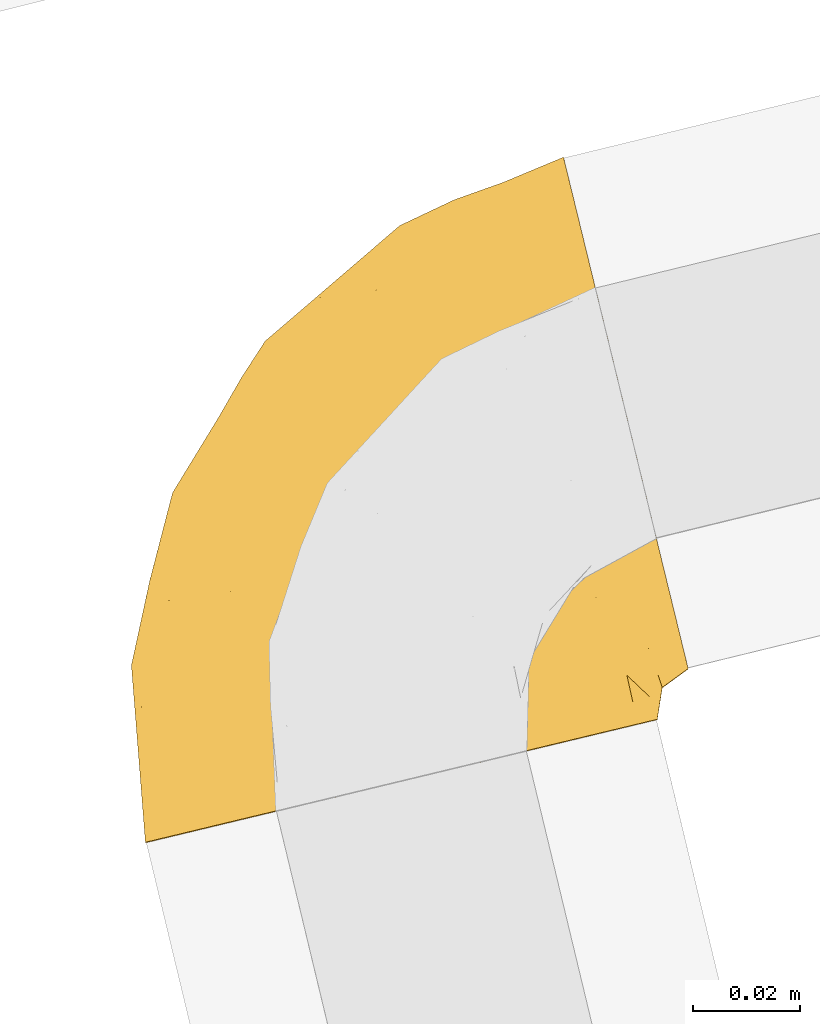
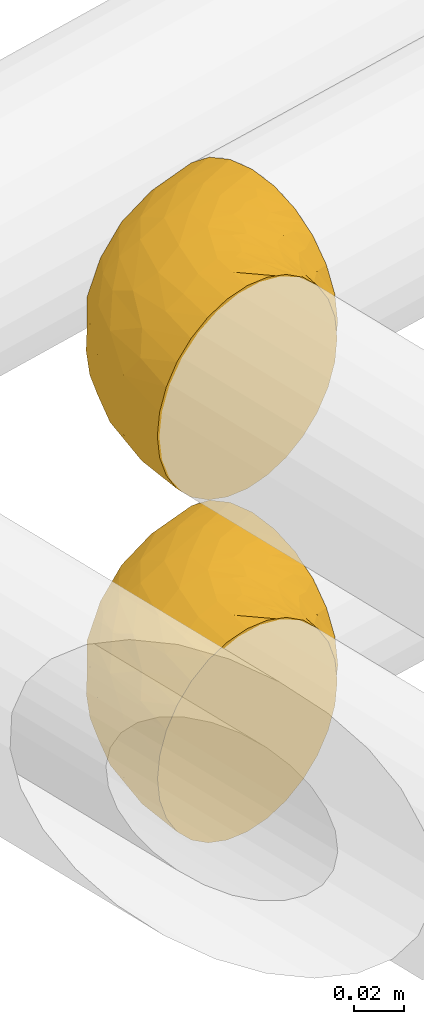
# One storey, part 10 of 93: 2 coverings.
"""IFC2X3 building model written with IfcOpenShell, lengths in millimetres."""

import ifcopenshell
import ifcopenshell.guid

model = None  # the IFC model being written
_history = None  # IfcOwnerHistory: only IFC2X3 demands one
_inside = {}  # id of a spatial element -> (the spatial element, [elements in it])
_under = {}  # id of a project, library or spatial element -> (it, [spatial elements below it])
_declared = {}  # id of a project -> (the project, [libraries it declares])
_typed = {}  # id of a type object -> (the type object, [elements of that type])
_made_of = {}  # id of a material, layer set ... -> (it, [elements and type objects made of it])


def new_model(schema):
    """Start an empty IFC model of exactly this schema.

    Asked for "IFC4X3", IfcOpenShell would pick the latest addendum, in which some entities
    have other attributes; the version numbers below select the first issue.
    IFC2X3 requires an IfcOwnerHistory on every rooted entity: one is made here for all.
    """
    global model, _history
    if schema == "IFC4X3":
        model = ifcopenshell.file(schema_version=(4, 3, 0, 0))
    else:
        model = ifcopenshell.file(schema=schema)
    _inside.clear()
    _under.clear()
    _declared.clear()
    _typed.clear()
    _made_of.clear()
    _history = None
    if model.schema == "IFC2X3":
        org = make("IfcOrganization", Name="unknown")
        user = make(
            "IfcPersonAndOrganization",
            ThePerson=make("IfcPerson", FamilyName="unknown"),
            TheOrganization=org,
        )
        app = make(
            "IfcApplication",
            ApplicationDeveloper=org,
            Version="unknown",
            ApplicationFullName="unknown",
            ApplicationIdentifier="unknown",
        )
        _history = make(
            "IfcOwnerHistory",
            OwningUser=user,
            OwningApplication=app,
            ChangeAction="ADDED",
            CreationDate=0,
        )
    return model


def make(cls, **values):
    """One entity of the class cls with the attributes given. An attribute that is None is left unset."""
    return model.create_entity(
        cls, **{name: value for name, value in values.items() if value is not None}
    )


def entity(cls, *values):
    """Any entity or typed value of the class cls, its attributes in the order of the schema. None: left unset."""
    e = model.create_entity(cls)
    for i, value in enumerate(values):
        if value is not None:
            e[i] = value
    return e


def rooted(cls, **values):
    """An entity with a GlobalId (a new one), such as an element, a storey or a relation."""
    return make(cls, GlobalId=ifcopenshell.guid.new(), OwnerHistory=_history, **values)


def si_unit(unit_type, name, prefix=None):
    """IfcSIUnit, for example si_unit("LENGTHUNIT", "METRE", prefix="MILLI")."""
    return make("IfcSIUnit", UnitType=unit_type, Prefix=prefix, Name=name)


def converted_unit(unit_type, name, factor, base, dimensions=None, offset=None):
    """IfcConversionBasedUnit, such as the inch: factor (a typed value) times the base unit."""
    return make(
        "IfcConversionBasedUnit"
        if offset is None
        else "IfcConversionBasedUnitWithOffset",
        ConversionOffset=offset,
        Dimensions=None
        if dimensions is None
        else entity("IfcDimensionalExponents", *dimensions),
        UnitType=unit_type,
        Name=name,
        ConversionFactor=make(
            "IfcMeasureWithUnit", ValueComponent=factor, UnitComponent=base
        ),
    )


def derived_unit(unit_type, elements):
    """IfcDerivedUnit: a product of units, each with its exponent."""
    return make(
        "IfcDerivedUnit",
        Elements=[
            make("IfcDerivedUnitElement", Unit=unit, Exponent=power)
            for unit, power in elements
        ],
        UnitType=unit_type,
    )


def assignment(units):
    """IfcUnitAssignment: the units of a project."""
    return None if units is None else make("IfcUnitAssignment", Units=units)


def point(xyz):
    """IfcCartesianPoint."""
    return None if xyz is None else make("IfcCartesianPoint", Coordinates=xyz)


def direction(xyz):
    """IfcDirection."""
    return None if xyz is None else make("IfcDirection", DirectionRatios=xyz)


def frame(location, z_axis=None, x_axis=None):
    """IfcAxis2Placement3D, a coordinate frame: its origin and axes. An axis left out is left unset."""
    return make(
        "IfcAxis2Placement3D",
        Location=point(location),
        Axis=direction(z_axis),
        RefDirection=direction(x_axis),
    )


def origin():
    """The frame at (0, 0, 0) with its axes left unset."""
    return frame((0.0, 0.0, 0.0))


def place(relative_to, where):
    """IfcLocalPlacement: puts the frame where relative to a parent placement (None: the world)."""
    return make(
        "IfcLocalPlacement", PlacementRelTo=relative_to, RelativePlacement=where
    )


def context(
    kind, dimensions, precision=None, world=None, true_north=None, identifier=None
):
    """IfcGeometricRepresentationContext, for example the 3D "Model" context."""
    return make(
        "IfcGeometricRepresentationContext",
        ContextIdentifier=identifier,
        ContextType=kind,
        CoordinateSpaceDimension=dimensions,
        Precision=precision,
        WorldCoordinateSystem=world,
        TrueNorth=true_north,
    )


def subcontext(parent, identifier, kind, view, scale=None):
    """IfcGeometricRepresentationSubContext, for example "Body" below "Model"."""
    return make(
        "IfcGeometricRepresentationSubContext",
        ContextIdentifier=identifier,
        ContextType=kind,
        ParentContext=parent,
        TargetScale=scale,
        TargetView=view,
    )


def project(units=None, contexts=None):
    """IfcProject with its units and contexts."""
    return rooted(
        "IfcProject",
        Name="project",
        RepresentationContexts=contexts,
        UnitsInContext=assignment(units),
    )


def spatial(cls, under=None, at=None, **own):
    """A site, building, storey or space (cls), placed at a placement, below another one or the project."""
    s = rooted(cls, ObjectPlacement=at, **own)
    if under is not None:
        _under.setdefault(under.id(), (under, []))[1].append(s)
    return s


def faces_of(points, faces, orient=None, outer=None):
    """IfcFace entities. A face is a list of loops; a loop is a list of indices into points, from 0.

    orient and outer hold one flag for each loop. By default every Orientation is true, the
    first loop of a face is its IfcFaceOuterBound and the others are IfcFaceBound.
    """
    made = []
    for i, loops in enumerate(faces):
        bounds = []
        for j, loop in enumerate(loops):
            is_outer = j == 0 if outer is None else outer[i][j]
            bounds.append(
                make(
                    "IfcFaceOuterBound" if is_outer else "IfcFaceBound",
                    Bound=make("IfcPolyLoop", Polygon=[points[k] for k in loop]),
                    Orientation=True if orient is None else orient[i][j],
                )
            )
        made.append(make("IfcFace", Bounds=bounds))
    return made


def faceted_brep(points, faces, orient=None, outer=None, voids=None):
    """IfcFacetedBrep: a solid bounded by flat faces; with voids (closed shells), ...WithVoids."""
    shared = [point(p) for p in points]
    hull = make("IfcClosedShell", CfsFaces=faces_of(shared, faces, orient, outer))
    if voids is None:
        return make("IfcFacetedBrep", Outer=hull)
    return make(
        "IfcFacetedBrepWithVoids",
        Outer=hull,
        Voids=[
            make(cls, CfsFaces=faces_of(shared, fs, o, b)) for cls, fs, o, b in voids
        ],
    )


def shape(context_of_items, identifier, shape_type, items):
    """IfcShapeRepresentation: the items that make up one representation, for example the "Body"."""
    return make(
        "IfcShapeRepresentation",
        ContextOfItems=context_of_items,
        RepresentationIdentifier=identifier,
        RepresentationType=shape_type,
        Items=items,
    )


def made_of(thing, what):
    """Note that an element or type object is made of a material, layer set ...; save() writes the relation."""
    if what is not None:
        _made_of.setdefault(what.id(), (what, []))[1].append(thing)
    return thing


def element(
    cls,
    number,
    at=None,
    inside=None,
    cuts=None,
    type_object=None,
    material=None,
    context=None,
    identifier="Body",
    shape_type=None,
    held_by="IfcProductDefinitionShape",
    body=None,
    shapes=None,
    **own,
):
    """One element of the class cls, such as IfcWall. Its Tag is "e" and its number.

    at: its placement. inside: the storey or other place that contains it. cuts: it is an
    opening in that element (IfcRelVoidsElement). A single representation is given by context,
    identifier, shape_type and body (its items); several are given by shapes. held_by: the class
    of the entity that holds the representations. save() writes the other relations.
    """
    e = rooted(cls, Tag="e%d" % number, ObjectPlacement=at, **own)
    if body is not None:
        shapes = [shape(context, identifier, shape_type, body)]
    if shapes is not None:
        e.Representation = make(held_by, Representations=shapes)
    if inside is not None:
        _inside.setdefault(inside.id(), (inside, []))[1].append(e)
    if cuts is not None:
        rooted(
            "IfcRelVoidsElement", RelatingBuildingElement=cuts, RelatedOpeningElement=e
        )
    if type_object is not None:
        _typed.setdefault(type_object.id(), (type_object, []))[1].append(e)
    return made_of(e, material)


def aggregate(whole, parts):
    """IfcRelAggregates: a whole, such as a stair, and the parts it consists of."""
    return rooted("IfcRelAggregates", RelatingObject=whole, RelatedObjects=parts)


def save(model, path):
    """Write the relations noted so far, then the file.

    IfcRelAggregates (storeys below a building ...), IfcRelContainedInSpatialStructure (elements
    in a storey), IfcRelDefinesByType, IfcRelAssociatesMaterial and IfcRelDeclares: one each for
    every whole, place, type object, material and project.
    """
    for whole, parts in _under.values():
        aggregate(whole, parts)
    for where, things in _inside.values():
        rooted(
            "IfcRelContainedInSpatialStructure",
            RelatedElements=things,
            RelatingStructure=where,
        )
    for kind, things in _typed.values():
        rooted("IfcRelDefinesByType", RelatedObjects=things, RelatingType=kind)
    for what, things in _made_of.values():
        rooted("IfcRelAssociatesMaterial", RelatedObjects=things, RelatingMaterial=what)
    for by, libraries in _declared.values():
        rooted("IfcRelDeclares", RelatingContext=by, RelatedDefinitions=libraries)
    model.write(path)


model = new_model("IFC2X3")

# Units and contexts
model_context = context("Model", 3, precision=0.01, world=origin(), true_north=direction((6.12303176911189e-17, 1.0)))
body_context = subcontext(model_context, "Body", "Model", "MODEL_VIEW")
ifc_project = project(units=[si_unit("LENGTHUNIT", "METRE", prefix="MILLI"), si_unit("AREAUNIT", "SQUARE_METRE"), si_unit("VOLUMEUNIT", "CUBIC_METRE"), converted_unit("PLANEANGLEUNIT", "DEGREE", entity("IfcRatioMeasure", 0.0174532925199433), si_unit("PLANEANGLEUNIT", "RADIAN"), dimensions=[0, 0, 0, 0, 0, 0, 0]), si_unit("MASSUNIT", "GRAM", prefix="KILO"), derived_unit("MASSDENSITYUNIT", [(si_unit("MASSUNIT", "GRAM", prefix="KILO"), 1), (si_unit("LENGTHUNIT", "METRE"), -3)]), derived_unit("MOMENTOFINERTIAUNIT", [(si_unit("LENGTHUNIT", "METRE"), 4)]), si_unit("TIMEUNIT", "SECOND"), si_unit("FREQUENCYUNIT", "HERTZ"), si_unit("THERMODYNAMICTEMPERATUREUNIT", "DEGREE_CELSIUS"), derived_unit("THERMALTRANSMITTANCEUNIT", [(si_unit("MASSUNIT", "GRAM", prefix="KILO"), 1), (si_unit("THERMODYNAMICTEMPERATUREUNIT", "KELVIN"), -1), (si_unit("TIMEUNIT", "SECOND"), -3)]), derived_unit("VOLUMETRICFLOWRATEUNIT", [(si_unit("LENGTHUNIT", "METRE"), 3), (si_unit("TIMEUNIT", "SECOND"), -1)]), derived_unit("MASSFLOWRATEUNIT", [(si_unit("MASSUNIT", "GRAM", prefix="KILO"), 1), (si_unit("TIMEUNIT", "SECOND"), -1)]), derived_unit("ROTATIONALFREQUENCYUNIT", [(si_unit("TIMEUNIT", "SECOND"), -1)]), si_unit("ELECTRICCURRENTUNIT", "AMPERE"), si_unit("ELECTRICVOLTAGEUNIT", "VOLT"), si_unit("POWERUNIT", "WATT"), si_unit("FORCEUNIT", "NEWTON", prefix="KILO"), si_unit("ILLUMINANCEUNIT", "LUX"), si_unit("LUMINOUSFLUXUNIT", "LUMEN"), si_unit("LUMINOUSINTENSITYUNIT", "CANDELA"), derived_unit("USERDEFINED", [(si_unit("MASSUNIT", "GRAM", prefix="KILO"), -1), (si_unit("LENGTHUNIT", "METRE"), -2), (si_unit("TIMEUNIT", "SECOND"), 3), (si_unit("LUMINOUSFLUXUNIT", "LUMEN"), 1)]), derived_unit("LINEARVELOCITYUNIT", [(si_unit("LENGTHUNIT", "METRE"), 1), (si_unit("TIMEUNIT", "SECOND"), -1)]), si_unit("PRESSUREUNIT", "PASCAL"), derived_unit("USERDEFINED", [(si_unit("LENGTHUNIT", "METRE"), -2), (si_unit("MASSUNIT", "GRAM", prefix="KILO"), 1), (si_unit("TIMEUNIT", "SECOND"), -2)]), derived_unit("LINEARFORCEUNIT", [(si_unit("MASSUNIT", "GRAM", prefix="KILO"), 1), (si_unit("LENGTHUNIT", "METRE"), 1), (si_unit("TIMEUNIT", "SECOND"), -2), (si_unit("LENGTHUNIT", "METRE"), -1)]), derived_unit("PLANARFORCEUNIT", [(si_unit("MASSUNIT", "GRAM", prefix="KILO"), 1), (si_unit("LENGTHUNIT", "METRE"), 1), (si_unit("TIMEUNIT", "SECOND"), -2), (si_unit("LENGTHUNIT", "METRE"), -2)])], contexts=[model_context])

# Site, building, storey
site_placement = place(None, origin())
site = spatial("IfcSite", under=ifc_project, at=site_placement, CompositionType="ELEMENT")
building_placement = place(site_placement, origin())
building = spatial("IfcBuilding", under=site, at=building_placement, CompositionType="ELEMENT")
storey_placement = place(building_placement, frame((0.0, 0.0, -4200.0)))
storey = spatial("IfcBuildingStorey", under=building, at=storey_placement, CompositionType="ELEMENT", Elevation=-4200.0)

# Coverings
covering_1_placement = place(storey_placement, frame((-15002.85, 11277.26, 2508.06)))
element("IfcCovering", 1, at=covering_1_placement, inside=storey, Name=":ADSK_", ObjectType=":ADSK_", PredefinedType="INSULATION", context=body_context, shape_type="Brep", body=[
    faceted_brep([(98.59, 24.27, 61.69), (95.06, 23.42, 72.08), (89.36, 22.06, 81.4), (81.79, 20.24, 89.18), (72.73, 18.06, 95.03), (67.68, 16.85, 96.85), (62.63, 15.63, 98.66), (57.55, 14.41, 99.25), (54.78, 13.75, 99.57), (52.0, 13.08, 99.9), (41.36, 10.52, 98.66), (31.26, 8.09, 95.02), (22.2, 5.92, 89.17), (14.63, 4.1, 81.38), (8.94, 2.73, 72.06), (5.41, 1.88, 61.68), (4.21, 1.6, 50.75), (5.41, 1.88, 39.8), (8.95, 2.73, 29.41), (14.65, 4.1, 20.09), (22.21, 5.92, 12.31), (31.27, 8.1, 6.46), (41.37, 10.53, 2.83), (52.0, 13.08, 1.6), (57.55, 14.41, 2.24), (62.64, 15.64, 2.83), (67.69, 16.85, 4.65), (72.75, 18.06, 6.47), (81.81, 20.24, 12.32), (89.37, 22.06, 20.11), (95.06, 23.43, 29.43), (98.6, 24.28, 39.81), (99.79, 24.56, 50.75), (105.17, 35.65, 38.02), (104.01, 40.42, 26.17), (102.16, 48.01, 15.99), (100.95, 52.95, 12.09), (99.75, 57.9, 8.18), (98.34, 63.66, 5.73), (96.94, 69.42, 3.27), (95.29, 76.19, 2.35), (94.61, 78.98, 1.97), (93.93, 81.78, 1.6), (90.91, 94.13, 3.27), (88.11, 105.65, 8.18), (85.7, 115.54, 15.99), (83.85, 123.13, 26.17), (82.68, 127.9, 38.02), (82.29, 129.53, 50.75), (82.68, 127.9, 63.47), (83.85, 123.13, 75.32), (85.7, 115.54, 85.5), (88.11, 105.65, 93.31), (90.91, 94.13, 98.22), (93.93, 81.78, 99.9), (95.29, 76.19, 99.14), (96.94, 69.42, 98.22), (98.34, 63.66, 95.77), (99.75, 57.9, 93.31), (100.95, 52.95, 89.4), (102.16, 48.01, 85.5), (104.01, 40.42, 75.32), (105.17, 35.65, 63.47), (105.57, 34.02, 50.75), (22.1, 88.27, 59.29), (31.62, 92.78, 73.11), (36.86, 103.34, 63.74), (51.71, 116.75, 50.75), (61.85, 121.55, 58.65), (70.99, 124.81, 50.75), (47.31, 104.68, 76.75), (59.77, 117.86, 67.69), (66.79, 114.77, 78.93), (30.04, 45.62, 94.32), (40.08, 31.35, 98.75), (43.55, 52.56, 98.4), (67.87, 95.07, 94.57), (46.31, 87.87, 89.92), (49.5, 74.59, 96.34), (73.18, 84.42, 98.79), (73.8, 72.42, 99.9), (78.85, 74.77, 99.9), (83.9, 77.12, 99.9), (86.41, 78.28, 99.9), (88.91, 79.45, 99.9), (62.57, 104.23, 87.32), (30.34, 26.16, 95.6), (5.02, 50.4, 60.46), (3.46, 26.85, 65.24), (8.62, 46.78, 72.88), (51.12, 35.26, 99.9), (53.03, 40.46, 99.9), (54.94, 45.67, 99.9), (56.86, 50.88, 99.9), (58.77, 56.09, 99.9), (21.74, 25.35, 90.65), (10.92, 66.7, 63.07), (36.83, 71.63, 91.92), (7.95, 21.36, 75.25), (3.25, 13.79, 50.75), (38.24, 91.15, 82.21), (28.61, 74.11, 85.12), (22.96, 77.25, 76.93), (9.29, 66.87, 50.75), (17.93, 81.02, 50.75), (13.42, 29.67, 83.02), (51.89, 15.84, 99.9), (51.78, 18.6, 99.9), (51.56, 24.12, 99.9), (51.34, 29.69, 99.9), (20.14, 48.45, 87.14), (17.83, 60.69, 80.74), (58.09, 69.34, 99.17), (1.6, 34.63, 50.75), (62.53, 60.17, 99.9), (66.28, 64.26, 99.9), (70.04, 68.34, 99.9), (26.56, 95.16, 50.75), (19.35, 80.15, 67.57), (13.72, 64.74, 72.15), (5.44, 50.75, 50.75), (39.13, 105.95, 50.75), (61.29, 24.22, 98.69), (89.28, 70.55, 99.01), (80.98, 64.75, 98.78), (87.37, 66.17, 98.29), (86.84, 30.02, 84.1), (95.25, 27.72, 71.06), (62.96, 36.25, 98.54), (58.6, 33.5, 99.29), (93.9, 49.51, 89.51), (96.72, 43.8, 83.59), (98.12, 37.75, 75.73), (91.82, 41.24, 84.77), (94.13, 32.79, 75.87), (99.93, 32.85, 64.77), (81.88, 39.14, 90.82), (74.78, 38.64, 94.63), (80.24, 32.78, 90.37), (95.65, 52.96, 91.18), (88.32, 57.81, 95.54), (81.74, 26.94, 88.63), (83.66, 44.18, 91.6), (88.34, 34.47, 83.9), (67.46, 27.33, 96.85), (100.72, 30.49, 50.75), (98.35, 28.78, 62.92), (65.38, 42.05, 98.37), (64.76, 47.61, 99.0), (71.79, 47.45, 97.35), (76.93, 61.48, 98.76), (84.25, 54.15, 95.26), (73.87, 54.23, 98.03), (88.39, 47.26, 90.61), (74.72, 27.22, 93.48), (74.13, 33.02, 94.16), (72.34, 59.43, 99.1), (98.13, 37.75, 25.77), (88.4, 47.26, 10.89), (96.73, 43.81, 17.9), (91.85, 41.25, 16.73), (95.26, 27.72, 30.45), (93.9, 49.51, 11.98), (67.47, 27.33, 4.64), (86.85, 30.02, 17.4), (91.42, 80.61, 1.6), (83.9, 77.12, 1.6), (88.91, 79.45, 1.6), (81.77, 26.95, 12.88), (80.25, 32.79, 11.13), (87.37, 66.17, 3.2), (88.32, 57.81, 5.95), (95.65, 52.96, 10.31), (74.76, 27.21, 8.04), (63.29, 36.09, 3.04), (74.14, 33.02, 7.34), (89.28, 70.55, 2.48), (76.93, 61.48, 2.73), (80.65, 64.97, 2.63), (51.56, 24.12, 1.6), (61.3, 24.23, 2.8), (99.93, 32.86, 36.71), (78.85, 74.77, 1.6), (73.8, 72.42, 1.6), (98.36, 28.79, 38.59), (51.78, 18.6, 1.6), (51.67, 21.36, 1.6), (65.39, 42.05, 3.12), (88.36, 34.48, 17.6), (56.86, 50.88, 1.6), (64.79, 47.62, 2.5), (74.79, 38.66, 6.86), (73.87, 54.22, 3.46), (83.69, 44.17, 9.91), (71.87, 47.43, 4.17), (51.34, 29.69, 1.6), (51.12, 35.26, 1.6), (94.14, 32.79, 25.63), (81.9, 39.15, 10.68), (72.35, 59.43, 2.39), (66.28, 64.26, 1.6), (84.25, 54.15, 6.23), (70.04, 68.34, 1.6), (58.61, 33.5, 2.2), (62.53, 60.17, 1.6), (58.77, 56.09, 1.6), (54.94, 45.67, 1.6), (53.03, 40.46, 1.6), (57.72, 69.56, 2.4), (61.85, 121.55, 42.84), (62.57, 104.23, 14.17), (46.53, 88.05, 11.55), (38.28, 91.16, 19.26), (47.3, 104.68, 24.74), (31.6, 92.74, 28.35), (30.2, 25.87, 5.95), (39.81, 31.49, 2.8), (73.18, 84.42, 2.7), (36.86, 103.33, 37.75), (59.77, 117.86, 33.8), (66.79, 114.77, 22.56), (67.87, 95.07, 6.92), (8.63, 46.78, 28.6), (3.47, 26.85, 36.23), (5.02, 50.41, 41.02), (22.92, 77.18, 24.55), (19.35, 80.15, 33.92), (30.01, 44.95, 7.1), (22.1, 88.27, 42.2), (13.43, 29.67, 18.45), (21.75, 25.35, 10.83), (17.76, 60.61, 20.8), (13.7, 64.73, 29.37), (43.52, 52.57, 3.1), (34.07, 65.67, 9.16), (10.93, 66.74, 38.45), (7.96, 21.36, 26.22), (20.2, 48.64, 14.34), (48.88, 74.98, 5.45), (28.62, 74.1, 16.36)], [[[0, 1, 2, 3, 4, 5, 6, 7, 8, 9, 10, 11, 12, 13, 14, 15, 16, 17, 18, 19, 20, 21, 22, 23, 24, 25, 26, 27, 28, 29, 30, 31, 32]], [[33, 34, 35, 36, 37, 38, 39, 40, 41, 42, 43, 44, 45, 46, 47, 48, 49, 50, 51, 52, 53, 54, 55, 56, 57, 58, 59, 60, 61, 62, 63]], [[64, 65, 66]], [[67, 68, 69]], [[66, 70, 71]], [[71, 70, 72]], [[73, 74, 75]], [[76, 77, 78]], [[50, 49, 71]], [[79, 80, 81, 82, 83, 84, 54]], [[51, 85, 52]], [[72, 51, 50]], [[11, 10, 86]], [[87, 88, 89]], [[75, 90, 91, 92, 93, 94]], [[54, 53, 79]], [[76, 52, 85]], [[14, 88, 15]], [[86, 74, 73]], [[95, 12, 11]], [[87, 89, 96]], [[97, 78, 77]], [[88, 14, 98]], [[72, 85, 51]], [[98, 14, 13]], [[88, 99, 15]], [[77, 100, 101]], [[100, 65, 102]], [[103, 96, 104]], [[105, 13, 12]], [[74, 9, 106, 107, 108, 109, 90]], [[105, 110, 111]], [[112, 75, 94]], [[87, 113, 88]], [[112, 94, 114, 115, 116, 80]], [[73, 95, 86]], [[117, 64, 66]], [[49, 69, 68]], [[98, 89, 88]], [[97, 75, 78]], [[100, 102, 101]], [[95, 105, 12]], [[78, 79, 76]], [[105, 95, 110]], [[66, 71, 68]], [[64, 96, 118]], [[76, 79, 53]], [[112, 79, 78]], [[52, 76, 53]], [[76, 85, 77]], [[100, 85, 70]], [[77, 101, 97]], [[13, 105, 98]], [[89, 98, 105]], [[86, 95, 11]], [[110, 95, 73]], [[97, 110, 73]], [[101, 102, 111]], [[89, 119, 96]], [[87, 103, 120, 113]], [[99, 88, 113]], [[99, 16, 15]], [[86, 10, 74]], [[9, 74, 10]], [[90, 75, 74]], [[71, 72, 50]], [[85, 72, 70]], [[79, 112, 80]], [[75, 112, 78]], [[85, 100, 77]], [[65, 100, 70]], [[66, 65, 70]], [[65, 118, 102]], [[118, 119, 102]], [[102, 119, 111]], [[119, 118, 96]], [[89, 105, 111]], [[89, 111, 119]], [[101, 111, 110]], [[104, 96, 64]], [[103, 87, 96]], [[104, 64, 117]], [[65, 64, 118]], [[66, 67, 121, 117]], [[49, 48, 69]], [[49, 68, 71]], [[110, 97, 101]], [[75, 97, 73]], [[67, 66, 68]], [[5, 122, 108]], [[82, 81, 123]], [[124, 80, 116]], [[58, 57, 125]], [[126, 1, 127]], [[128, 91, 129]], [[60, 130, 131]], [[132, 133, 134]], [[135, 63, 62]], [[62, 132, 135]], [[136, 137, 138]], [[109, 108, 122, 90]], [[132, 134, 135]], [[132, 62, 61]], [[139, 59, 140]], [[123, 57, 56]], [[141, 126, 138]], [[141, 2, 126]], [[125, 81, 80]], [[4, 122, 5]], [[106, 9, 8, 7, 6, 108, 107]], [[6, 5, 108]], [[142, 136, 143]], [[4, 144, 122]], [[56, 55, 54, 84, 83, 82]], [[145, 146, 32]], [[146, 135, 134]], [[1, 126, 2]], [[93, 92, 147]], [[1, 0, 127]], [[143, 136, 126]], [[122, 144, 129]], [[125, 57, 123]], [[148, 137, 149]], [[125, 124, 140]], [[140, 58, 125]], [[150, 140, 124]], [[151, 152, 153]], [[151, 130, 139]], [[144, 4, 3]], [[141, 154, 3]], [[155, 147, 128]], [[131, 61, 60]], [[132, 131, 133]], [[134, 127, 146]], [[63, 135, 145]], [[156, 150, 115]], [[150, 116, 115]], [[151, 140, 150]], [[156, 114, 152]], [[142, 149, 136]], [[151, 150, 156]], [[130, 151, 153]], [[130, 153, 131]], [[151, 139, 140]], [[133, 131, 153]], [[132, 61, 131]], [[142, 133, 153]], [[142, 143, 133]], [[153, 152, 142]], [[149, 142, 152]], [[152, 94, 149]], [[147, 92, 128]], [[80, 124, 125]], [[116, 150, 124]], [[94, 93, 148]], [[137, 147, 155]], [[148, 93, 147]], [[91, 90, 129]], [[128, 144, 154]], [[128, 92, 91]], [[127, 0, 146]], [[127, 134, 143]], [[32, 146, 0]], [[145, 135, 146]], [[82, 123, 56]], [[125, 123, 81]], [[138, 137, 155]], [[149, 137, 136]], [[138, 155, 141]], [[136, 138, 126]], [[154, 141, 155]], [[3, 2, 141]], [[128, 154, 155]], [[144, 3, 154]], [[122, 129, 90]], [[128, 129, 144]], [[127, 143, 126]], [[133, 143, 134]], [[59, 139, 60]], [[59, 58, 140]], [[130, 60, 139]], [[114, 94, 152]], [[151, 156, 152]], [[156, 115, 114]], [[137, 148, 147]], [[94, 148, 149]], [[34, 33, 157]], [[158, 159, 160]], [[31, 30, 161]], [[35, 159, 162]], [[28, 27, 163]], [[164, 30, 29]], [[165, 42, 41, 40, 39, 166, 167]], [[168, 169, 164]], [[170, 37, 171]], [[36, 35, 172]], [[173, 174, 175]], [[39, 176, 166]], [[177, 178, 171]], [[26, 179, 180]], [[63, 145, 181]], [[182, 170, 183]], [[32, 31, 184]], [[170, 38, 37]], [[24, 23, 185, 186, 179, 25]], [[176, 39, 38]], [[187, 175, 174]], [[188, 161, 164]], [[33, 181, 157]], [[175, 169, 168]], [[189, 190, 187]], [[27, 180, 163]], [[169, 175, 191]], [[192, 193, 194]], [[195, 196, 180, 179]], [[179, 26, 25]], [[27, 26, 180]], [[197, 157, 181]], [[188, 164, 198]], [[184, 161, 197]], [[199, 200, 177]], [[182, 176, 170]], [[158, 201, 162]], [[202, 178, 177]], [[202, 177, 200]], [[196, 203, 180]], [[203, 174, 163]], [[168, 173, 175]], [[197, 188, 160]], [[162, 159, 158]], [[63, 181, 33]], [[161, 184, 31]], [[171, 201, 177]], [[170, 178, 183]], [[201, 192, 199]], [[193, 158, 160]], [[192, 204, 199]], [[36, 172, 171]], [[192, 201, 158]], [[171, 162, 201]], [[159, 35, 34]], [[34, 157, 159]], [[160, 159, 157]], [[197, 160, 157]], [[160, 188, 193]], [[194, 193, 198]], [[192, 158, 193]], [[187, 191, 175]], [[205, 192, 194]], [[183, 178, 202]], [[171, 178, 170]], [[187, 206, 189]], [[205, 194, 190]], [[191, 194, 198]], [[164, 161, 30]], [[206, 187, 174]], [[207, 203, 196]], [[207, 206, 174]], [[184, 197, 181]], [[181, 145, 184]], [[32, 184, 145]], [[170, 176, 38]], [[166, 176, 182]], [[191, 187, 190]], [[169, 198, 164]], [[198, 169, 191]], [[168, 164, 29]], [[29, 28, 168]], [[173, 168, 28]], [[28, 163, 173]], [[174, 173, 163]], [[174, 203, 207]], [[180, 203, 163]], [[188, 198, 193]], [[161, 188, 197]], [[171, 37, 36]], [[35, 162, 172]], [[162, 171, 172]], [[201, 199, 177]], [[205, 190, 189]], [[204, 192, 205]], [[204, 200, 199]], [[191, 190, 194]], [[208, 183, 202, 200, 204, 205]], [[47, 209, 69]], [[210, 211, 212]], [[213, 212, 214]], [[215, 216, 22]], [[217, 42, 165, 167, 166, 182, 183]], [[218, 219, 213]], [[46, 45, 220]], [[209, 47, 219]], [[210, 221, 211]], [[221, 44, 43]], [[220, 219, 46]], [[46, 219, 47]], [[220, 210, 213]], [[222, 223, 224]], [[210, 45, 44]], [[225, 226, 214]], [[42, 217, 43]], [[216, 215, 227]], [[218, 214, 228]], [[23, 22, 216]], [[223, 18, 17]], [[19, 229, 20]], [[20, 230, 21]], [[231, 222, 232]], [[233, 205, 189, 206, 207, 196]], [[234, 233, 227]], [[221, 43, 217]], [[104, 228, 235]], [[223, 236, 18]], [[230, 237, 227]], [[18, 236, 19]], [[113, 223, 99]], [[238, 233, 234]], [[230, 20, 229]], [[222, 229, 236]], [[223, 17, 99]], [[222, 235, 232]], [[224, 113, 120, 103]], [[215, 21, 230]], [[208, 233, 238]], [[209, 218, 67]], [[218, 213, 214]], [[228, 117, 218]], [[208, 217, 183]], [[238, 211, 221]], [[238, 221, 217]], [[44, 221, 210]], [[234, 211, 238]], [[212, 211, 239]], [[222, 236, 223]], [[229, 19, 236]], [[237, 230, 229]], [[215, 230, 227]], [[231, 229, 222]], [[234, 237, 239]], [[113, 224, 223]], [[232, 235, 226]], [[17, 16, 99]], [[233, 208, 205]], [[217, 208, 238]], [[216, 227, 233]], [[22, 21, 215]], [[233, 196, 216]], [[216, 196, 195, 179, 186, 185, 23]], [[210, 220, 45]], [[219, 220, 213]], [[69, 209, 67]], [[69, 48, 47]], [[218, 209, 219]], [[225, 214, 212]], [[210, 212, 213]], [[225, 212, 239]], [[214, 226, 228]], [[231, 239, 237]], [[232, 226, 225]], [[231, 232, 225]], [[235, 222, 224]], [[239, 231, 225]], [[231, 237, 229]], [[224, 103, 235]], [[235, 103, 104]], [[235, 228, 226]], [[121, 67, 218, 117]], [[104, 117, 228]], [[237, 234, 227]], [[211, 234, 239]]]),
])
covering_2_placement = place(storey_placement, frame((-15002.84, 11277.15, 2342.1)))
element("IfcCovering", 2, at=covering_2_placement, inside=storey, Name=":ADSK_", ObjectType=":ADSK_", PredefinedType="INSULATION", context=body_context, shape_type="Brep", body=[
    faceted_brep([(98.6, 24.3, 61.69), (95.06, 23.45, 72.08), (89.36, 22.08, 81.4), (81.8, 20.26, 89.18), (72.73, 18.08, 95.03), (67.68, 16.86, 96.85), (62.63, 15.65, 98.66), (57.56, 14.43, 99.25), (54.78, 13.76, 99.57), (52.01, 13.09, 99.9), (41.37, 10.53, 98.66), (31.27, 8.1, 95.02), (22.21, 5.92, 89.17), (14.64, 4.1, 81.38), (8.95, 2.73, 72.06), (5.42, 1.88, 61.68), (4.22, 1.6, 50.75), (5.42, 1.88, 39.8), (8.96, 2.73, 29.41), (14.65, 4.1, 20.09), (22.22, 5.92, 12.31), (31.28, 8.1, 6.46), (41.38, 10.53, 2.83), (52.01, 13.09, 1.6), (57.56, 14.43, 2.24), (62.65, 15.65, 2.83), (67.7, 16.86, 4.65), (72.75, 18.08, 6.47), (81.81, 20.26, 12.32), (89.37, 22.08, 20.11), (95.07, 23.45, 29.43), (98.6, 24.3, 39.81), (99.79, 24.58, 50.75), (105.17, 35.67, 38.02), (104.01, 40.44, 26.17), (102.16, 48.03, 15.99), (100.95, 52.98, 12.09), (99.75, 57.92, 8.18), (98.34, 63.68, 5.73), (96.94, 69.44, 3.27), (95.29, 76.22, 2.35), (94.61, 79.01, 1.97), (93.93, 81.8, 1.6), (90.91, 94.16, 3.27), (88.11, 105.67, 8.18), (85.7, 115.56, 15.99), (83.85, 123.15, 26.17), (82.68, 127.92, 38.02), (82.29, 129.55, 50.75), (82.68, 127.92, 63.47), (83.85, 123.15, 75.32), (85.7, 115.56, 85.5), (88.11, 105.67, 93.31), (90.91, 94.16, 98.22), (93.93, 81.8, 99.9), (95.29, 76.22, 99.14), (96.94, 69.44, 98.22), (98.34, 63.68, 95.77), (99.75, 57.92, 93.31), (100.95, 52.98, 89.4), (102.16, 48.03, 85.5), (104.01, 40.44, 75.32), (105.17, 35.67, 63.47), (105.57, 34.05, 50.75), (22.09, 88.29, 59.29), (31.61, 92.8, 73.11), (36.86, 103.36, 63.74), (51.7, 116.77, 50.75), (61.85, 121.58, 58.65), (71.0, 124.83, 50.75), (47.3, 104.7, 76.75), (59.77, 117.89, 67.69), (66.79, 114.79, 78.93), (30.04, 45.63, 94.32), (40.08, 31.36, 98.75), (43.55, 52.57, 98.4), (67.87, 95.09, 94.57), (46.31, 87.89, 89.92), (49.49, 74.61, 96.34), (73.18, 84.44, 98.79), (73.8, 72.44, 99.9), (78.85, 74.79, 99.9), (83.91, 77.14, 99.9), (86.41, 78.31, 99.9), (88.92, 79.47, 99.9), (62.57, 104.25, 87.32), (30.34, 26.17, 95.6), (5.02, 50.4, 60.46), (3.46, 26.85, 65.24), (8.62, 46.79, 72.88), (51.12, 35.27, 99.9), (53.03, 40.48, 99.9), (54.94, 45.69, 99.9), (56.86, 50.9, 99.9), (58.77, 56.11, 99.9), (21.74, 25.35, 90.65), (10.92, 66.71, 63.07), (36.83, 71.65, 91.92), (7.95, 21.36, 75.25), (3.25, 13.79, 50.75), (38.23, 91.17, 82.2), (28.6, 74.12, 85.12), (22.97, 77.28, 76.93), (9.29, 66.88, 50.75), (17.92, 81.03, 50.75), (13.42, 29.67, 83.02), (51.9, 15.85, 99.9), (51.79, 18.61, 99.9), (51.56, 24.13, 99.9), (51.34, 29.7, 99.9), (20.13, 48.46, 87.14), (17.84, 60.72, 80.75), (58.08, 69.36, 99.17), (1.6, 34.64, 50.75), (62.53, 60.19, 99.9), (66.28, 64.28, 99.9), (70.04, 68.36, 99.9), (26.55, 95.18, 50.75), (19.35, 80.16, 67.57), (13.72, 64.75, 72.15), (5.44, 50.76, 50.75), (39.13, 105.97, 50.75), (61.29, 24.23, 98.69), (89.28, 70.57, 99.01), (80.98, 64.77, 98.78), (87.37, 66.19, 98.29), (86.84, 30.03, 84.1), (95.25, 27.74, 71.06), (62.96, 36.27, 98.54), (58.6, 33.52, 99.29), (93.9, 49.53, 89.5), (96.72, 43.82, 83.58), (98.12, 37.77, 75.73), (91.82, 41.26, 84.78), (94.13, 32.81, 75.87), (99.93, 32.88, 64.77), (81.88, 39.16, 90.82), (74.78, 38.66, 94.63), (80.24, 32.79, 90.37), (95.65, 52.98, 91.18), (81.74, 26.96, 88.63), (83.65, 44.21, 91.61), (88.34, 34.49, 83.9), (67.45, 27.34, 96.86), (100.73, 30.51, 50.75), (98.35, 28.81, 62.92), (65.38, 42.07, 98.37), (64.75, 47.63, 99.0), (71.75, 47.48, 97.36), (88.32, 57.83, 95.54), (76.93, 61.5, 98.76), (84.25, 54.18, 95.26), (73.86, 54.25, 98.03), (88.39, 47.29, 90.61), (74.72, 27.23, 93.48), (74.13, 33.03, 94.16), (72.34, 59.45, 99.1), (98.13, 37.77, 25.76), (88.4, 47.29, 10.89), (96.73, 43.83, 17.9), (91.84, 41.27, 16.73), (95.26, 27.74, 30.45), (93.9, 49.53, 11.98), (67.47, 27.34, 4.64), (86.85, 30.04, 17.4), (83.91, 77.14, 1.6), (88.92, 79.47, 1.6), (91.42, 80.63, 1.6), (81.77, 26.97, 12.88), (80.25, 32.81, 11.13), (87.37, 66.19, 3.2), (88.32, 57.83, 5.95), (95.65, 52.98, 10.31), (74.76, 27.23, 8.04), (63.28, 36.11, 3.03), (74.14, 33.03, 7.34), (89.28, 70.57, 2.48), (76.93, 61.5, 2.73), (80.65, 64.99, 2.63), (51.56, 24.13, 1.6), (61.3, 24.25, 2.8), (99.93, 32.88, 36.71), (78.85, 74.79, 1.6), (73.8, 72.44, 1.6), (98.36, 28.81, 38.59), (51.79, 18.61, 1.6), (51.68, 21.37, 1.6), (65.39, 42.07, 3.12), (88.36, 34.5, 17.6), (56.86, 50.9, 1.6), (64.78, 47.64, 2.5), (74.79, 38.68, 6.86), (73.87, 54.24, 3.46), (83.68, 44.2, 9.9), (71.83, 47.46, 4.15), (51.34, 29.7, 1.6), (51.12, 35.27, 1.6), (94.14, 32.81, 25.63), (81.89, 39.17, 10.68), (72.34, 59.45, 2.39), (66.28, 64.28, 1.6), (84.25, 54.18, 6.23), (70.04, 68.36, 1.6), (58.61, 33.51, 2.2), (62.53, 60.19, 1.6), (58.77, 56.11, 1.6), (54.94, 45.69, 1.6), (53.03, 40.48, 1.6), (57.72, 69.58, 2.4), (61.85, 121.58, 42.84), (62.57, 104.25, 14.17), (46.53, 88.08, 11.55), (38.27, 91.18, 19.26), (47.3, 104.7, 24.74), (31.6, 92.76, 28.35), (30.2, 25.88, 5.95), (39.81, 31.5, 2.8), (73.18, 84.44, 2.7), (36.86, 103.36, 37.75), (59.77, 117.88, 33.8), (66.79, 114.79, 22.56), (67.87, 95.09, 6.92), (8.63, 46.78, 28.6), (3.47, 26.85, 36.23), (5.02, 50.41, 41.02), (22.93, 77.21, 24.55), (19.35, 80.16, 33.92), (30.01, 44.96, 7.1), (22.09, 88.29, 42.2), (13.43, 29.68, 18.45), (21.75, 25.35, 10.83), (17.77, 60.64, 20.79), (13.7, 64.74, 29.36), (43.52, 52.59, 3.1), (34.07, 65.68, 9.16), (10.93, 66.74, 38.45), (7.96, 21.36, 26.22), (20.19, 48.64, 14.34), (48.88, 74.99, 5.45), (28.61, 74.12, 16.36)], [[[0, 1, 2, 3, 4, 5, 6, 7, 8, 9, 10, 11, 12, 13, 14, 15, 16, 17, 18, 19, 20, 21, 22, 23, 24, 25, 26, 27, 28, 29, 30, 31, 32]], [[33, 34, 35, 36, 37, 38, 39, 40, 41, 42, 43, 44, 45, 46, 47, 48, 49, 50, 51, 52, 53, 54, 55, 56, 57, 58, 59, 60, 61, 62, 63]], [[64, 65, 66]], [[67, 68, 69]], [[66, 70, 71]], [[71, 70, 72]], [[73, 74, 75]], [[76, 77, 78]], [[50, 49, 71]], [[79, 80, 81, 82, 83, 84, 54]], [[51, 85, 52]], [[72, 51, 50]], [[11, 10, 86]], [[87, 88, 89]], [[75, 90, 91, 92, 93, 94]], [[54, 53, 79]], [[76, 52, 85]], [[14, 88, 15]], [[86, 74, 73]], [[95, 12, 11]], [[87, 89, 96]], [[97, 78, 77]], [[88, 14, 98]], [[72, 85, 51]], [[98, 14, 13]], [[88, 99, 15]], [[77, 100, 101]], [[100, 65, 102]], [[103, 96, 104]], [[105, 13, 12]], [[74, 9, 106, 107, 108, 109, 90]], [[105, 110, 111]], [[112, 75, 94]], [[87, 113, 88]], [[112, 94, 114, 115, 116, 80]], [[73, 95, 86]], [[117, 64, 66]], [[49, 69, 68]], [[98, 89, 88]], [[97, 75, 78]], [[100, 102, 101]], [[95, 105, 12]], [[78, 79, 76]], [[105, 95, 110]], [[66, 71, 68]], [[64, 96, 118]], [[76, 79, 53]], [[112, 79, 78]], [[52, 76, 53]], [[76, 85, 77]], [[100, 85, 70]], [[77, 101, 97]], [[13, 105, 98]], [[89, 98, 105]], [[86, 95, 11]], [[110, 95, 73]], [[97, 110, 73]], [[101, 102, 111]], [[89, 119, 96]], [[87, 103, 120, 113]], [[99, 88, 113]], [[99, 16, 15]], [[86, 10, 74]], [[9, 74, 10]], [[90, 75, 74]], [[71, 72, 50]], [[85, 72, 70]], [[79, 112, 80]], [[75, 112, 78]], [[85, 100, 77]], [[65, 100, 70]], [[66, 65, 70]], [[65, 118, 102]], [[118, 119, 102]], [[102, 119, 111]], [[119, 118, 96]], [[89, 105, 111]], [[89, 111, 119]], [[101, 111, 110]], [[64, 117, 104]], [[103, 87, 96]], [[66, 67, 121, 117]], [[96, 64, 104]], [[64, 118, 65]], [[49, 48, 69]], [[49, 68, 71]], [[110, 97, 101]], [[75, 97, 73]], [[67, 66, 68]], [[5, 122, 108]], [[82, 81, 123]], [[124, 80, 116]], [[58, 57, 125]], [[126, 1, 127]], [[128, 91, 129]], [[60, 130, 131]], [[132, 133, 134]], [[135, 63, 62]], [[62, 132, 135]], [[136, 137, 138]], [[109, 108, 122, 90]], [[132, 134, 135]], [[132, 62, 61]], [[130, 60, 139]], [[123, 57, 56]], [[140, 126, 138]], [[140, 2, 126]], [[125, 81, 80]], [[4, 122, 5]], [[106, 9, 8, 7, 6, 108, 107]], [[6, 5, 108]], [[141, 136, 142]], [[4, 143, 122]], [[56, 55, 54, 84, 83, 82]], [[144, 145, 32]], [[145, 135, 134]], [[1, 126, 2]], [[93, 92, 146]], [[1, 0, 127]], [[142, 136, 126]], [[122, 143, 129]], [[125, 57, 123]], [[147, 137, 148]], [[125, 124, 149]], [[149, 58, 125]], [[150, 149, 124]], [[151, 152, 153]], [[151, 130, 139]], [[143, 4, 3]], [[140, 154, 3]], [[155, 146, 128]], [[131, 61, 60]], [[132, 131, 133]], [[134, 127, 145]], [[63, 135, 144]], [[156, 150, 115]], [[150, 116, 115]], [[151, 149, 150]], [[156, 114, 152]], [[141, 148, 136]], [[151, 150, 156]], [[130, 151, 153]], [[130, 153, 131]], [[139, 60, 59]], [[133, 131, 153]], [[132, 61, 131]], [[141, 133, 153]], [[141, 142, 133]], [[153, 152, 141]], [[148, 141, 152]], [[152, 94, 148]], [[146, 92, 128]], [[80, 124, 125]], [[116, 150, 124]], [[94, 93, 147]], [[137, 146, 155]], [[147, 93, 146]], [[91, 90, 129]], [[128, 143, 154]], [[128, 92, 91]], [[127, 0, 145]], [[127, 134, 142]], [[32, 145, 0]], [[144, 135, 145]], [[82, 123, 56]], [[125, 123, 81]], [[138, 137, 155]], [[148, 137, 136]], [[138, 155, 140]], [[136, 138, 126]], [[154, 140, 155]], [[3, 2, 140]], [[128, 154, 155]], [[143, 3, 154]], [[122, 129, 90]], [[128, 129, 143]], [[127, 142, 126]], [[133, 142, 134]], [[59, 149, 139]], [[58, 149, 59]], [[139, 149, 151]], [[114, 94, 152]], [[151, 156, 152]], [[156, 115, 114]], [[137, 147, 146]], [[94, 147, 148]], [[34, 33, 157]], [[158, 159, 160]], [[31, 30, 161]], [[35, 159, 162]], [[28, 27, 163]], [[164, 30, 29]], [[41, 40, 39, 165, 166, 167, 42]], [[168, 169, 164]], [[170, 37, 171]], [[36, 35, 172]], [[173, 174, 175]], [[39, 176, 165]], [[177, 178, 171]], [[26, 179, 180]], [[63, 144, 181]], [[182, 170, 183]], [[32, 31, 184]], [[170, 38, 37]], [[24, 23, 185, 186, 179, 25]], [[176, 39, 38]], [[187, 175, 174]], [[188, 161, 164]], [[33, 181, 157]], [[175, 169, 168]], [[189, 190, 187]], [[27, 180, 163]], [[169, 175, 191]], [[192, 193, 194]], [[195, 196, 180, 179]], [[179, 26, 25]], [[27, 26, 180]], [[197, 157, 181]], [[188, 164, 198]], [[184, 161, 197]], [[199, 200, 177]], [[182, 176, 170]], [[158, 201, 162]], [[202, 178, 177]], [[202, 177, 200]], [[196, 203, 180]], [[203, 174, 163]], [[168, 173, 175]], [[197, 188, 160]], [[162, 159, 158]], [[63, 181, 33]], [[161, 184, 31]], [[171, 201, 177]], [[170, 178, 183]], [[201, 192, 199]], [[193, 158, 160]], [[192, 204, 199]], [[36, 172, 171]], [[192, 201, 158]], [[172, 201, 171]], [[159, 35, 34]], [[34, 157, 159]], [[160, 159, 157]], [[197, 160, 157]], [[160, 188, 193]], [[194, 193, 198]], [[192, 158, 193]], [[187, 191, 175]], [[205, 192, 194]], [[183, 178, 202]], [[171, 178, 170]], [[187, 206, 189]], [[205, 194, 190]], [[191, 194, 198]], [[164, 161, 30]], [[206, 187, 174]], [[207, 203, 196]], [[207, 206, 174]], [[184, 197, 181]], [[181, 144, 184]], [[32, 184, 144]], [[170, 176, 38]], [[165, 176, 182]], [[191, 187, 190]], [[169, 198, 164]], [[198, 169, 191]], [[168, 164, 29]], [[29, 28, 168]], [[173, 168, 28]], [[28, 163, 173]], [[174, 173, 163]], [[174, 203, 207]], [[180, 203, 163]], [[188, 198, 193]], [[161, 188, 197]], [[171, 37, 36]], [[35, 162, 172]], [[201, 172, 162]], [[201, 199, 177]], [[205, 190, 189]], [[204, 192, 205]], [[204, 200, 199]], [[191, 190, 194]], [[208, 183, 202, 200, 204, 205]], [[47, 209, 69]], [[210, 211, 212]], [[213, 212, 214]], [[215, 216, 22]], [[217, 42, 167, 166, 165, 182, 183]], [[218, 219, 213]], [[46, 45, 220]], [[209, 47, 219]], [[210, 221, 211]], [[221, 44, 43]], [[220, 219, 46]], [[46, 219, 47]], [[220, 210, 213]], [[222, 223, 224]], [[210, 45, 44]], [[225, 226, 214]], [[42, 217, 43]], [[216, 215, 227]], [[214, 228, 218]], [[23, 22, 216]], [[223, 18, 17]], [[19, 229, 20]], [[20, 230, 21]], [[231, 222, 232]], [[233, 205, 189, 206, 207, 196]], [[234, 233, 227]], [[221, 43, 217]], [[104, 228, 235]], [[223, 236, 18]], [[230, 237, 227]], [[18, 236, 19]], [[113, 223, 99]], [[238, 233, 234]], [[230, 20, 229]], [[222, 229, 236]], [[223, 17, 99]], [[222, 235, 232]], [[224, 113, 120, 103]], [[215, 21, 230]], [[208, 233, 238]], [[209, 218, 67]], [[218, 213, 214]], [[228, 117, 218]], [[208, 217, 183]], [[238, 211, 221]], [[238, 221, 217]], [[44, 221, 210]], [[234, 211, 238]], [[212, 211, 239]], [[222, 236, 223]], [[229, 19, 236]], [[237, 230, 229]], [[215, 230, 227]], [[231, 229, 222]], [[234, 237, 239]], [[113, 224, 223]], [[232, 235, 226]], [[17, 16, 99]], [[233, 208, 205]], [[217, 208, 238]], [[216, 227, 233]], [[22, 21, 215]], [[233, 196, 216]], [[216, 196, 195, 179, 186, 185, 23]], [[210, 220, 45]], [[219, 220, 213]], [[69, 209, 67]], [[69, 48, 47]], [[218, 209, 219]], [[225, 214, 212]], [[210, 212, 213]], [[225, 212, 239]], [[214, 226, 228]], [[231, 239, 237]], [[232, 226, 225]], [[231, 232, 225]], [[235, 222, 224]], [[239, 231, 225]], [[231, 237, 229]], [[224, 103, 235]], [[235, 103, 104]], [[228, 104, 117]], [[67, 218, 117, 121]], [[235, 228, 226]], [[237, 234, 227]], [[211, 234, 239]]]),
])

save(model, "model.ifc")
